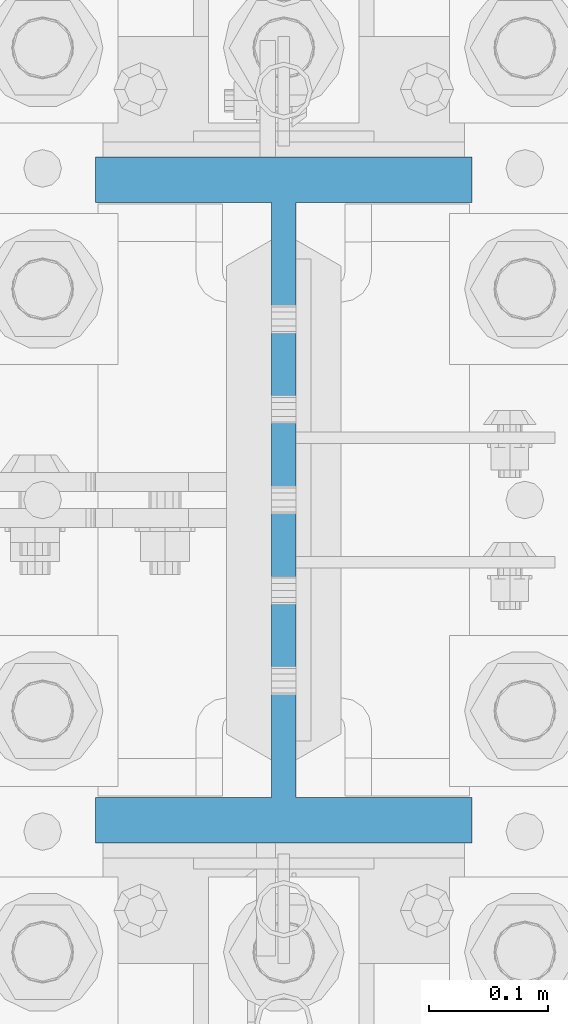
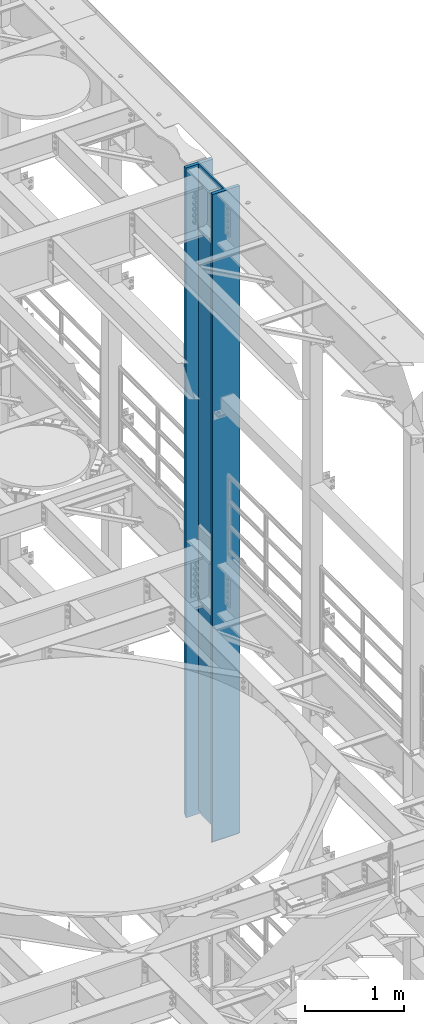
# One storey, part 714 of 1876: 1 column, 1 element without a shape of its own.
"""IFC2X3 building model written with IfcOpenShell, lengths in millimetres."""

import ifcopenshell
import ifcopenshell.guid

model = None  # the IFC model being written
_history = None  # IfcOwnerHistory: only IFC2X3 demands one
_inside = {}  # id of a spatial element -> (the spatial element, [elements in it])
_under = {}  # id of a project, library or spatial element -> (it, [spatial elements below it])
_declared = {}  # id of a project -> (the project, [libraries it declares])
_typed = {}  # id of a type object -> (the type object, [elements of that type])
_made_of = {}  # id of a material, layer set ... -> (it, [elements and type objects made of it])


def new_model(schema):
    """Start an empty IFC model of exactly this schema.

    Asked for "IFC4X3", IfcOpenShell would pick the latest addendum, in which some entities
    have other attributes; the version numbers below select the first issue.
    IFC2X3 requires an IfcOwnerHistory on every rooted entity: one is made here for all.
    """
    global model, _history
    if schema == "IFC4X3":
        model = ifcopenshell.file(schema_version=(4, 3, 0, 0))
    else:
        model = ifcopenshell.file(schema=schema)
    _inside.clear()
    _under.clear()
    _declared.clear()
    _typed.clear()
    _made_of.clear()
    _history = None
    if model.schema == "IFC2X3":
        org = make("IfcOrganization", Name="unknown")
        user = make(
            "IfcPersonAndOrganization",
            ThePerson=make("IfcPerson", FamilyName="unknown"),
            TheOrganization=org,
        )
        app = make(
            "IfcApplication",
            ApplicationDeveloper=org,
            Version="unknown",
            ApplicationFullName="unknown",
            ApplicationIdentifier="unknown",
        )
        _history = make(
            "IfcOwnerHistory",
            OwningUser=user,
            OwningApplication=app,
            ChangeAction="ADDED",
            CreationDate=0,
        )
    return model


def make(cls, **values):
    """One entity of the class cls with the attributes given. An attribute that is None is left unset."""
    return model.create_entity(
        cls, **{name: value for name, value in values.items() if value is not None}
    )


def rooted(cls, **values):
    """An entity with a GlobalId (a new one), such as an element, a storey or a relation."""
    return make(cls, GlobalId=ifcopenshell.guid.new(), OwnerHistory=_history, **values)


def si_unit(unit_type, name, prefix=None):
    """IfcSIUnit, for example si_unit("LENGTHUNIT", "METRE", prefix="MILLI")."""
    return make("IfcSIUnit", UnitType=unit_type, Prefix=prefix, Name=name)


def assignment(units):
    """IfcUnitAssignment: the units of a project."""
    return None if units is None else make("IfcUnitAssignment", Units=units)


def point(xyz):
    """IfcCartesianPoint."""
    return None if xyz is None else make("IfcCartesianPoint", Coordinates=xyz)


def direction(xyz):
    """IfcDirection."""
    return None if xyz is None else make("IfcDirection", DirectionRatios=xyz)


def frame(location, z_axis=None, x_axis=None):
    """IfcAxis2Placement3D, a coordinate frame: its origin and axes. An axis left out is left unset."""
    return make(
        "IfcAxis2Placement3D",
        Location=point(location),
        Axis=direction(z_axis),
        RefDirection=direction(x_axis),
    )


def origin_with_axes():
    """The frame at (0, 0, 0) with the z axis (0, 0, 1) and the x axis (1, 0, 0) written out."""
    return frame((0.0, 0.0, 0.0), z_axis=(0.0, 0.0, 1.0), x_axis=(1.0, 0.0, 0.0))


def place(relative_to, where):
    """IfcLocalPlacement: puts the frame where relative to a parent placement (None: the world)."""
    return make(
        "IfcLocalPlacement", PlacementRelTo=relative_to, RelativePlacement=where
    )


def context(
    kind, dimensions, precision=None, world=None, true_north=None, identifier=None
):
    """IfcGeometricRepresentationContext, for example the 3D "Model" context."""
    return make(
        "IfcGeometricRepresentationContext",
        ContextIdentifier=identifier,
        ContextType=kind,
        CoordinateSpaceDimension=dimensions,
        Precision=precision,
        WorldCoordinateSystem=world,
        TrueNorth=true_north,
    )


def subcontext(parent, identifier, kind, view, scale=None):
    """IfcGeometricRepresentationSubContext, for example "Body" below "Model"."""
    return make(
        "IfcGeometricRepresentationSubContext",
        ContextIdentifier=identifier,
        ContextType=kind,
        ParentContext=parent,
        TargetScale=scale,
        TargetView=view,
    )


def project(units=None, contexts=None):
    """IfcProject with its units and contexts."""
    return rooted(
        "IfcProject",
        Name="project",
        RepresentationContexts=contexts,
        UnitsInContext=assignment(units),
    )


def spatial(cls, under=None, at=None, **own):
    """A site, building, storey or space (cls), placed at a placement, below another one or the project."""
    s = rooted(cls, ObjectPlacement=at, **own)
    if under is not None:
        _under.setdefault(under.id(), (under, []))[1].append(s)
    return s


def faces_of(points, faces, orient=None, outer=None):
    """IfcFace entities. A face is a list of loops; a loop is a list of indices into points, from 0.

    orient and outer hold one flag for each loop. By default every Orientation is true, the
    first loop of a face is its IfcFaceOuterBound and the others are IfcFaceBound.
    """
    made = []
    for i, loops in enumerate(faces):
        bounds = []
        for j, loop in enumerate(loops):
            is_outer = j == 0 if outer is None else outer[i][j]
            bounds.append(
                make(
                    "IfcFaceOuterBound" if is_outer else "IfcFaceBound",
                    Bound=make("IfcPolyLoop", Polygon=[points[k] for k in loop]),
                    Orientation=True if orient is None else orient[i][j],
                )
            )
        made.append(make("IfcFace", Bounds=bounds))
    return made


def faceted_brep(points, faces, orient=None, outer=None, voids=None):
    """IfcFacetedBrep: a solid bounded by flat faces; with voids (closed shells), ...WithVoids."""
    shared = [point(p) for p in points]
    hull = make("IfcClosedShell", CfsFaces=faces_of(shared, faces, orient, outer))
    if voids is None:
        return make("IfcFacetedBrep", Outer=hull)
    return make(
        "IfcFacetedBrepWithVoids",
        Outer=hull,
        Voids=[
            make(cls, CfsFaces=faces_of(shared, fs, o, b)) for cls, fs, o, b in voids
        ],
    )


def shape(context_of_items, identifier, shape_type, items):
    """IfcShapeRepresentation: the items that make up one representation, for example the "Body"."""
    return make(
        "IfcShapeRepresentation",
        ContextOfItems=context_of_items,
        RepresentationIdentifier=identifier,
        RepresentationType=shape_type,
        Items=items,
    )


def material(Name=None, Category=None):
    """IfcMaterial."""
    return make("IfcMaterial", Name=Name, Category=Category)


def made_of(thing, what):
    """Note that an element or type object is made of a material, layer set ...; save() writes the relation."""
    if what is not None:
        _made_of.setdefault(what.id(), (what, []))[1].append(thing)
    return thing


def type_object(cls, material=None, **own):
    """A type object (cls), such as IfcWallType, which elements share."""
    return made_of(rooted(cls, **own), material)


def element(
    cls,
    number,
    at=None,
    inside=None,
    cuts=None,
    type_object=None,
    material=None,
    context=None,
    identifier="Body",
    shape_type=None,
    held_by="IfcProductDefinitionShape",
    body=None,
    shapes=None,
    **own,
):
    """One element of the class cls, such as IfcWall. Its Tag is "e" and its number.

    at: its placement. inside: the storey or other place that contains it. cuts: it is an
    opening in that element (IfcRelVoidsElement). A single representation is given by context,
    identifier, shape_type and body (its items); several are given by shapes. held_by: the class
    of the entity that holds the representations. save() writes the other relations.
    """
    e = rooted(cls, Tag="e%d" % number, ObjectPlacement=at, **own)
    if body is not None:
        shapes = [shape(context, identifier, shape_type, body)]
    if shapes is not None:
        e.Representation = make(held_by, Representations=shapes)
    if inside is not None:
        _inside.setdefault(inside.id(), (inside, []))[1].append(e)
    if cuts is not None:
        rooted(
            "IfcRelVoidsElement", RelatingBuildingElement=cuts, RelatedOpeningElement=e
        )
    if type_object is not None:
        _typed.setdefault(type_object.id(), (type_object, []))[1].append(e)
    return made_of(e, material)


def aggregate(whole, parts):
    """IfcRelAggregates: a whole, such as a stair, and the parts it consists of."""
    return rooted("IfcRelAggregates", RelatingObject=whole, RelatedObjects=parts)


def save(model, path):
    """Write the relations noted so far, then the file.

    IfcRelAggregates (storeys below a building ...), IfcRelContainedInSpatialStructure (elements
    in a storey), IfcRelDefinesByType, IfcRelAssociatesMaterial and IfcRelDeclares: one each for
    every whole, place, type object, material and project.
    """
    for whole, parts in _under.values():
        aggregate(whole, parts)
    for where, things in _inside.values():
        rooted(
            "IfcRelContainedInSpatialStructure",
            RelatedElements=things,
            RelatingStructure=where,
        )
    for kind, things in _typed.values():
        rooted("IfcRelDefinesByType", RelatedObjects=things, RelatingType=kind)
    for what, things in _made_of.values():
        rooted("IfcRelAssociatesMaterial", RelatedObjects=things, RelatingMaterial=what)
    for by, libraries in _declared.values():
        rooted("IfcRelDeclares", RelatingContext=by, RelatedDefinitions=libraries)
    model.write(path)


model = new_model("IFC2X3")

# Units and contexts
model_context = context("Model", 3, precision=1e-05, world=origin_with_axes())
body_context = subcontext(model_context, "Body", "Model", "MODEL_VIEW")
ifc_project = project(units=[si_unit("LENGTHUNIT", "METRE", prefix="MILLI"), si_unit("AREAUNIT", "SQUARE_METRE"), si_unit("VOLUMEUNIT", "CUBIC_METRE"), si_unit("MASSUNIT", "GRAM", prefix="KILO"), si_unit("TIMEUNIT", "SECOND"), si_unit("PLANEANGLEUNIT", "RADIAN"), si_unit("SOLIDANGLEUNIT", "STERADIAN"), si_unit("THERMODYNAMICTEMPERATUREUNIT", "DEGREE_CELSIUS"), si_unit("LUMINOUSINTENSITYUNIT", "LUMEN")], contexts=[model_context])

# Site, building, storey
site_placement = place(None, origin_with_axes())
site = spatial("IfcSite", under=ifc_project, at=site_placement, CompositionType="ELEMENT")
building_placement = place(site_placement, origin_with_axes())
building = spatial("IfcBuilding", under=site, at=building_placement, Name="Undefined", CompositionType="ELEMENT")
storey_placement = place(building_placement, origin_with_axes())
storey = spatial("IfcBuildingStorey", under=building, at=storey_placement, Name="Undefined", CompositionType="ELEMENT", Elevation=0.0)

# Assembly, column
assembly_placement = place(storey_placement, origin_with_axes())
assembly = element("IfcElementAssembly", 1, at=assembly_placement, inside=storey, Name="COLUMN", AssemblyPlace="NOTDEFINED", PredefinedType="RIGID_FRAME")
ifc_material = material(Name="STEEL/A992")
column_type = type_object("IfcColumnType", Name="W21X182", PredefinedType="NOTDEFINED")
column_placement = place(assembly_placement, frame((7620.0, 1524.0, 14528.8), z_axis=(0.0, 1.0, 0.0), x_axis=(0.0, 0.0, 1.0)))
column = element("IfcColumn", 2, at=column_placement, type_object=column_type, material=ifc_material, Name="COLUMN", ObjectType="W21X182", context=body_context, shape_type="Brep", body=[
    faceted_brep([(23.8124996185343, -10.3187499999995, 203.498507902429), (6.35000000000036, 7.14374961853082, 200.025000762939), (6.35000000000036, 7.14374961853082, -200.025000762939), (23.8124996185343, -10.3187500000004, -203.49850776611), (25.7903188351174, -10.3187500000004, -203.891920453291), (25.7903188351174, 10.3187500000004, -203.891920453291), (42.2710247077321, 10.3187500000004, -214.903976055203), (42.2710247077321, -10.3187500000004, -214.903976055203), (53.283080309644, 10.3187500000004, -231.384681927818), (53.283080309644, -10.3187500000004, -231.384681927818), (8026.4, -158.75, 288.925), (8026.4, 158.75, 288.925), (41.2749999999833, 158.75, 288.925), (41.2749999999833, -158.75, 288.925), (6.35000000000036, -158.75, 250.825), (57.1499992370573, -158.75, 250.825), (8026.4, -158.75, 250.825), (6.35000000000036, -158.75, 254.00000000002), (6.35000000000036, -10.3187500000004, 250.825), (6.35000000000036, 158.75, 254.00000000002), (6.35000000000036, 158.75, 250.825), (6.35000000000036, 10.3187500000004, 250.825), (6.35000000000036, 7.14374961853082, 250.825), (8026.4, 158.75, 250.825), (57.1499992370573, 158.75, 250.825), (57.1499992370573, 10.3187500000004, 250.825), (8026.4, 10.3187500000004, 250.825), (53.2830795467053, -10.3187500000004, 231.384681927818), (53.2830795467053, 10.3187500000004, 231.384681927818), (42.2710239447933, 10.3187500000004, 214.903976055203), (42.2710239447933, -10.3187500000004, 214.903976055203), (57.1499992370573, -10.3187500000004, 250.825), (23.8124996185343, -10.3187500000004, 250.825), (8026.4, -10.3187500000004, 250.825), (57.149999999996, 158.75, -250.825), (6.35000000000036, 158.75, -250.825), (6.35000000000036, 10.3187500000004, -250.825), (57.1499999999978, 10.3187500000004, -250.825), (8026.4, 10.3187500000004, -250.825), (8026.4, 158.75, -250.825), (8026.4, 158.75, -288.925), (8026.4, -158.75, -288.925), (41.2749999999833, -158.75, -288.925), (41.2749999999833, 158.75, -288.925), (8026.4, -158.75, -250.825), (57.149999999996, -158.75, -250.825), (6.35000000000036, -158.75, -250.825), (6.35000000000036, -158.75, -254.000000000019), (6.35000000000036, 158.75, -254.000000000019), (8026.4, -10.3187500000004, -250.825), (57.149999999996, -10.3187500000004, -250.825), (23.8124996185343, -10.3187500000004, -250.825), (6.35000000000036, -10.3187500000004, -250.825), (6.35000000000036, 7.14374961853082, -250.825), (6.35000000000036, 10.3187500000004, -200.025000762939), (6.35000000000036, 10.3187500000004, 200.025000762939), (25.7903180721787, 10.3187500000004, 203.891920453291), (25.7903180721787, -10.3187500000004, 203.891920453291)], [[[0, 1, 2, 3]], [[4, 5, 6, 7]], [[7, 6, 8, 9]], [[10, 11, 12, 13]], [[14, 15, 16, 10, 13, 17]], [[18, 14, 17, 19, 20, 21, 22]], [[13, 12, 19, 17]], [[11, 23, 24, 20, 19, 12]], [[25, 21, 20, 24, 23, 26]], [[27, 28, 29, 30]], [[31, 25, 28, 27]], [[32, 18, 22, 21, 25, 31]], [[15, 14, 18, 32, 31, 33, 16]], [[34, 35, 36, 37, 38, 39]], [[40, 41, 42, 43]], [[41, 44, 45, 46, 47, 42]], [[42, 47, 48, 43]], [[35, 34, 39, 40, 43, 48]], [[38, 26, 23, 11, 10, 16, 33, 49, 44, 41, 40, 39]], [[50, 51, 52, 46, 45, 44, 49]], [[36, 35, 48, 47, 46, 52, 53]], [[51, 50, 37, 36, 53, 52]], [[9, 8, 37, 50]], [[6, 5, 54, 55, 56, 29, 28, 25, 26, 38, 37, 8]], [[30, 29, 56, 57]], [[4, 7, 9, 50, 49, 33, 31, 27, 30, 57, 0, 3]], [[54, 5, 4, 3, 2]], [[55, 54, 2, 1]], [[57, 56, 55, 1, 0]]]),
])
aggregate(assembly, [column])

save(model, "model.ifc")
